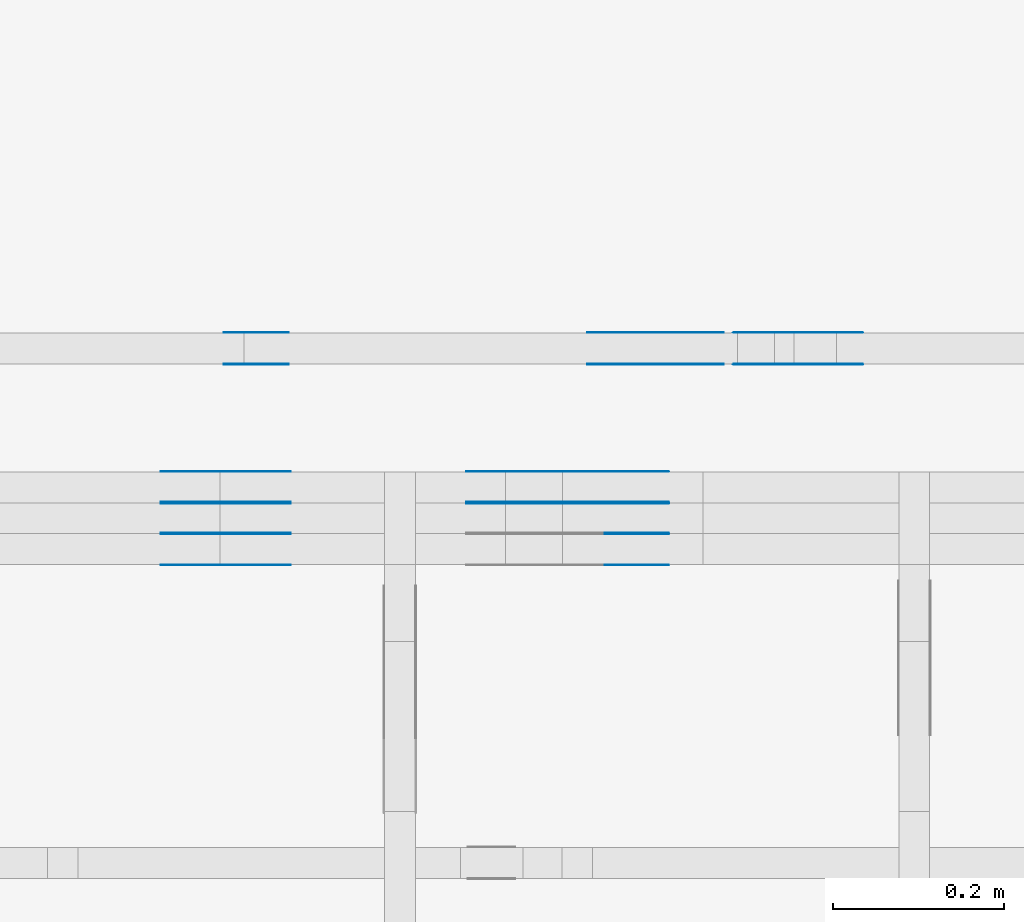
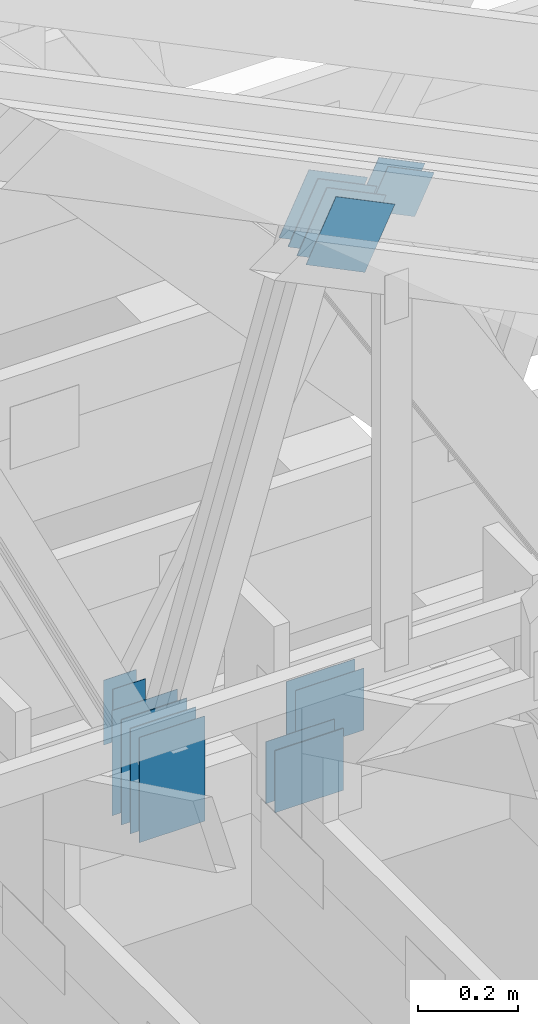
# One storey, part 127 of 159: 21 plates, 2 elements without a shape of their own.
"""IFC2X3 building model written with IfcOpenShell, lengths in millimetres."""

from ifc_helpers import new_model, si_unit, frame, origin, origin_with_axes, origin_2d, place, context, project, spatial, faceted_brep, element, aggregate, save


model = new_model("IFC2X3")

# Units and contexts
model_context = context("Model", 3, precision=1e-05, world=origin())
plan_context = context("Plan", 2, precision=1e-05, world=origin_2d())
ifc_project = project(units=[si_unit("LENGTHUNIT", "METRE", prefix="MILLI"), si_unit("AREAUNIT", "SQUARE_METRE"), si_unit("VOLUMEUNIT", "CUBIC_METRE"), si_unit("SOLIDANGLEUNIT", "STERADIAN"), si_unit("PLANEANGLEUNIT", "RADIAN"), si_unit("MASSUNIT", "GRAM"), si_unit("TIMEUNIT", "SECOND"), si_unit("THERMODYNAMICTEMPERATUREUNIT", "DEGREE_CELSIUS"), si_unit("LUMINOUSINTENSITYUNIT", "LUMEN")], contexts=[model_context, plan_context])

# Site, building, storey
site_placement = place(None, origin_with_axes())
site = spatial("IfcSite", under=ifc_project, at=site_placement, CompositionType="ELEMENT")
building_placement = place(site_placement, origin_with_axes())
building = spatial("IfcBuilding", under=site, at=building_placement, Name="Plan 1", CompositionType="ELEMENT")
storey_placement = place(building_placement, origin_with_axes())
storey = spatial("IfcBuildingStorey", under=building, at=storey_placement, Name="Etasje 1", CompositionType="ELEMENT", Elevation=0.0)

# Assembly, plates
assembly_1_placement = place(storey_placement, frame((10700.012663101485, 8801.999999990367, 0.0), z_axis=(0.0, -1.0, 6.123031769111886e-17), x_axis=(1.0, 0.0, 0.0)))
assembly_1 = element("IfcElementAssembly", 1, at=assembly_1_placement, inside=storey, Name="T8 (1)", AssemblyPlace="FACTORY", PredefinedType="TRUSS")
plate_1_placement = place(assembly_1_placement, frame((5070.5, 146.99999999999977, -73.0), z_axis=(0.0, 0.0, 1.0), x_axis=(1.0, 0.0, 0.0)))
plate_1 = element("IfcPlate", 2, at=plate_1_placement, Name="GNT100S 152x159", context=model_context, shape_type="Brep", body=[
    faceted_brep([(159.0, 152.00000000000023, 1.0), (0.0, 152.00000000000023, 1.0), (0.0, 2.2737367544323206e-13, 1.0), (159.0, 2.2737367544323206e-13, 1.0), (0.0, 152.00000000000023, 0.0), (159.0, 152.00000000000023, 1.9471241025775798e-14), (159.0, 2.2737367544323206e-13, 1.9471241025775798e-14), (0.0, 2.2737367544323206e-13, 0.0), (159.0, -2.92068615386637e-14, 1.788345410772899e-30), (159.0, -2.914563122097258e-14, 1.0), (1.1247455413666031e-32, 6.123031769111886e-17, 1.0), (0.0, 0.0, 0.0), (159.0, 152.0, 0.0), (159.0, 152.0, 1.0), (159.0, 0.0, 1.0), (159.0, 0.0, 0.0), (0.0, 152.0, 0.0), (-3.7491518045553436e-33, 152.0, 1.0), (159.0, 152.0, 1.0), (159.0, 152.0, 0.0), (0.0, 0.0, 0.0), (6.123031769111886e-17, -7.498303609110687e-33, 1.0), (1.8675246895791253e-14, 152.0, 1.0), (1.8614016578100134e-14, 152.0, -1.1397421485848245e-30)], [[[0, 1, 2, 3]], [[4, 5, 6, 7]], [[8, 9, 10, 11]], [[12, 13, 14, 15]], [[16, 17, 18, 19]], [[20, 21, 22, 23]]]),
])
plate_2_placement = place(assembly_1_placement, frame((5070.5, 146.99999999999977, -72.0), z_axis=(0.0, 0.0, 1.0), x_axis=(1.0, 0.0, 0.0)))
plate_2 = element("IfcPlate", 3, at=plate_2_placement, Name="GNT100S 152x159", context=model_context, shape_type="Brep", body=[
    faceted_brep([(159.0, 152.00000000000023, 1.0), (0.0, 152.00000000000023, 1.0), (0.0, 2.2737367544323206e-13, 1.0), (159.0, 2.2737367544323206e-13, 1.0), (0.0, 152.00000000000023, 0.0), (159.0, 152.00000000000023, 1.9471241025775798e-14), (159.0, 2.2737367544323206e-13, 1.9471241025775798e-14), (0.0, 2.2737367544323206e-13, 0.0), (159.0, -2.92068615386637e-14, 1.788345410772899e-30), (159.0, -2.914563122097258e-14, 1.0), (1.1247455413666031e-32, 6.123031769111886e-17, 1.0), (0.0, 0.0, 0.0), (159.0, 152.0, 0.0), (159.0, 152.0, 1.0), (159.0, 0.0, 1.0), (159.0, 0.0, 0.0), (0.0, 152.0, 0.0), (-3.7491518045553436e-33, 152.0, 1.0), (159.0, 152.0, 1.0), (159.0, 152.0, 0.0), (0.0, 0.0, 0.0), (6.123031769111886e-17, -7.498303609110687e-33, 1.0), (1.8675246895791253e-14, 152.0, 1.0), (1.8614016578100134e-14, 152.0, -1.1397421485848245e-30)], [[[0, 1, 2, 3]], [[4, 5, 6, 7]], [[8, 9, 10, 11]], [[12, 13, 14, 15]], [[16, 17, 18, 19]], [[20, 21, 22, 23]]]),
])
plate_3_placement = place(assembly_1_placement, frame((5070.5, 146.99999999999977, -109.0), z_axis=(0.0, 0.0, 1.0), x_axis=(1.0, 0.0, 0.0)))
plate_3 = element("IfcPlate", 4, at=plate_3_placement, Name="GNT100S 152x159", context=model_context, shape_type="Brep", body=[
    faceted_brep([(159.0, 152.00000000000023, 1.0), (0.0, 152.00000000000023, 1.0), (0.0, 2.2737367544323206e-13, 1.0), (159.0, 2.2737367544323206e-13, 1.0), (0.0, 152.00000000000023, 0.0), (159.0, 152.00000000000023, 1.9471241025775798e-14), (159.0, 2.2737367544323206e-13, 1.9471241025775798e-14), (0.0, 2.2737367544323206e-13, 0.0), (159.0, -2.92068615386637e-14, 1.788345410772899e-30), (159.0, -2.914563122097258e-14, 1.0), (1.1247455413666031e-32, 6.123031769111886e-17, 1.0), (0.0, 0.0, 0.0), (159.0, 152.0, 0.0), (159.0, 152.0, 1.0), (159.0, 0.0, 1.0), (159.0, 0.0, 0.0), (0.0, 152.0, 0.0), (-3.7491518045553436e-33, 152.0, 1.0), (159.0, 152.0, 1.0), (159.0, 152.0, 0.0), (0.0, 0.0, 0.0), (6.123031769111886e-17, -7.498303609110687e-33, 1.0), (1.8675246895791253e-14, 152.0, 1.0), (1.8614016578100134e-14, 152.0, -1.1397421485848245e-30)], [[[0, 1, 2, 3]], [[4, 5, 6, 7]], [[8, 9, 10, 11]], [[12, 13, 14, 15]], [[16, 17, 18, 19]], [[20, 21, 22, 23]]]),
])
plate_4_placement = place(assembly_1_placement, frame((5170.803078161007, 1667.5447482094141, 0.0), z_axis=(0.0, 0.0, 1.0), x_axis=(-0.4383711467890776, -0.8987940462991671, 0.0)))
plate_4 = element("IfcPlate", 5, at=plate_4_placement, Name="GNT100S 152x159", context=model_context, shape_type="Brep", body=[
    faceted_brep([(159.00016140741445, 152.00017854164298, 1.0), (2.6907896426564548e-05, 152.00017854164298, 1.0), (0.0, 0.00016076568863354623, 1.0), (159.00013449951803, 0.00016076568863354623, 1.0), (2.6907896426564548e-05, 152.00017854164298, 3.2951580931965386e-21), (159.00016140741445, 152.00017854164298, 1.9471260791830328e-14), (159.00013449951803, 4.886593887931667e-05, 1.9471257496672233e-14), (0.0, 4.886593887931667e-05, 0.0), (159.0001335586112, 9.593357614535953e-13, -3.0517839183092646e-30), (159.0001335586112, 9.593969917712864e-13, 1.0), (0.00013355861119634937, 6.12721837107411e-17, 1.0), (0.00013355861119634937, 4.18660196222441e-20, -2.563469681932617e-36), (159.0001335586112, 152.0000000000009, 0.0), (159.0001335586112, 152.0000000000009, 1.0), (159.0001335586112, 9.094947017729282e-13, 1.0), (159.0001335586112, 9.094947017729282e-13, 0.0), (0.00013355861119634937, 152.0, 0.0), (0.00013355861119634937, 152.0, 1.0), (159.0001335586112, 152.0000000000009, 1.0), (159.0001335586112, 152.0000000000009, 0.0), (0.00013355861119634937, 0.0, 0.0), (0.0001335586111964106, -7.498303609110687e-33, 1.0), (0.00013355861121502462, 152.0, 1.0), (0.0001335586112149634, 152.0, -1.1397427715968304e-30)], [[[0, 1, 2, 3]], [[4, 5, 6, 7]], [[8, 9, 10, 11]], [[12, 13, 14, 15]], [[16, 17, 18, 19]], [[20, 21, 22, 23]]]),
])
plate_5_placement = place(assembly_1_placement, frame((5170.803078161007, 1667.5447482094141, -37.00000000000001), z_axis=(0.0, 0.0, 1.0), x_axis=(-0.4383711467890776, -0.8987940462991671, 0.0)))
plate_5 = element("IfcPlate", 6, at=plate_5_placement, Name="GNT100S 152x159", context=model_context, shape_type="Brep", body=[
    faceted_brep([(159.00016140741445, 152.00017854164298, 1.0), (2.6907896426564548e-05, 152.00017854164298, 1.0), (0.0, 0.00016076568863354623, 1.0), (159.00013449951803, 0.00016076568863354623, 1.0), (2.6907896426564548e-05, 152.00017854164298, 3.2951580931965386e-21), (159.00016140741445, 152.00017854164298, 1.9471260791830328e-14), (159.00013449951803, 4.886593887931667e-05, 1.9471257496672233e-14), (0.0, 4.886593887931667e-05, 0.0), (159.0001335586112, 9.593357614535953e-13, -3.0517839183092646e-30), (159.0001335586112, 9.593969917712864e-13, 1.0), (0.00013355861119634937, 6.12721837107411e-17, 1.0), (0.00013355861119634937, 4.18660196222441e-20, -2.563469681932617e-36), (159.0001335586112, 152.0000000000009, 0.0), (159.0001335586112, 152.0000000000009, 1.0), (159.0001335586112, 9.094947017729282e-13, 1.0), (159.0001335586112, 9.094947017729282e-13, 0.0), (0.00013355861119634937, 152.0, 0.0), (0.00013355861119634937, 152.0, 1.0), (159.0001335586112, 152.0000000000009, 1.0), (159.0001335586112, 152.0000000000009, 0.0), (0.00013355861119634937, 0.0, 0.0), (0.0001335586111964106, -7.498303609110687e-33, 1.0), (0.00013355861121502462, 152.0, 1.0), (0.0001335586112149634, 152.0, -1.1397427715968304e-30)], [[[0, 1, 2, 3]], [[4, 5, 6, 7]], [[8, 9, 10, 11]], [[12, 13, 14, 15]], [[16, 17, 18, 19]], [[20, 21, 22, 23]]]),
])
plate_6_placement = place(assembly_1_placement, frame((5170.803078161007, 1667.5447482094141, -36.00000000000001), z_axis=(0.0, 0.0, 1.0), x_axis=(-0.4383711467890776, -0.8987940462991671, 0.0)))
plate_6 = element("IfcPlate", 7, at=plate_6_placement, Name="GNT100S 152x159", context=model_context, shape_type="Brep", body=[
    faceted_brep([(159.00016140741445, 152.00017854164298, 1.0), (2.6907896426564548e-05, 152.00017854164298, 1.0), (0.0, 0.00016076568863354623, 1.0), (159.00013449951803, 0.00016076568863354623, 1.0), (2.6907896426564548e-05, 152.00017854164298, 3.2951580931965386e-21), (159.00016140741445, 152.00017854164298, 1.9471260791830328e-14), (159.00013449951803, 4.886593887931667e-05, 1.9471257496672233e-14), (0.0, 4.886593887931667e-05, 0.0), (159.0001335586112, 9.593357614535953e-13, -3.0517839183092646e-30), (159.0001335586112, 9.593969917712864e-13, 1.0), (0.00013355861119634937, 6.12721837107411e-17, 1.0), (0.00013355861119634937, 4.18660196222441e-20, -2.563469681932617e-36), (159.0001335586112, 152.0000000000009, 0.0), (159.0001335586112, 152.0000000000009, 1.0), (159.0001335586112, 9.094947017729282e-13, 1.0), (159.0001335586112, 9.094947017729282e-13, 0.0), (0.00013355861119634937, 152.0, 0.0), (0.00013355861119634937, 152.0, 1.0), (159.0001335586112, 152.0000000000009, 1.0), (159.0001335586112, 152.0000000000009, 0.0), (0.00013355861119634937, 0.0, 0.0), (0.0001335586111964106, -7.498303609110687e-33, 1.0), (0.00013355861121502462, 152.0, 1.0), (0.0001335586112149634, 152.0, -1.1397427715968304e-30)], [[[0, 1, 2, 3]], [[4, 5, 6, 7]], [[8, 9, 10, 11]], [[12, 13, 14, 15]], [[16, 17, 18, 19]], [[20, 21, 22, 23]]]),
])
plate_7_placement = place(assembly_1_placement, frame((5170.803078161007, 1667.5447482094141, -73.00000000000001), z_axis=(0.0, 0.0, 1.0), x_axis=(-0.4383711467890776, -0.8987940462991671, 0.0)))
plate_7 = element("IfcPlate", 8, at=plate_7_placement, Name="GNT100S 152x159", context=model_context, shape_type="Brep", body=[
    faceted_brep([(159.00016140741445, 152.00017854164298, 1.0), (2.6907896426564548e-05, 152.00017854164298, 1.0), (0.0, 0.00016076568863354623, 1.0), (159.00013449951803, 0.00016076568863354623, 1.0), (2.6907896426564548e-05, 152.00017854164298, 3.2951580931965386e-21), (159.00016140741445, 152.00017854164298, 1.9471260791830328e-14), (159.00013449951803, 4.886593887931667e-05, 1.9471257496672233e-14), (0.0, 4.886593887931667e-05, 0.0), (159.0001335586112, 9.593357614535953e-13, -3.0517839183092646e-30), (159.0001335586112, 9.593969917712864e-13, 1.0), (0.00013355861119634937, 6.12721837107411e-17, 1.0), (0.00013355861119634937, 4.18660196222441e-20, -2.563469681932617e-36), (159.0001335586112, 152.0000000000009, 0.0), (159.0001335586112, 152.0000000000009, 1.0), (159.0001335586112, 9.094947017729282e-13, 1.0), (159.0001335586112, 9.094947017729282e-13, 0.0), (0.00013355861119634937, 152.0, 0.0), (0.00013355861119634937, 152.0, 1.0), (159.0001335586112, 152.0000000000009, 1.0), (159.0001335586112, 152.0000000000009, 0.0), (0.00013355861119634937, 0.0, 0.0), (0.0001335586111964106, -7.498303609110687e-33, 1.0), (0.00013355861121502462, 152.0, 1.0), (0.0001335586112149634, 152.0, -1.1397427715968304e-30)], [[[0, 1, 2, 3]], [[4, 5, 6, 7]], [[8, 9, 10, 11]], [[12, 13, 14, 15]], [[16, 17, 18, 19]], [[20, 21, 22, 23]]]),
])
plate_8_placement = place(assembly_1_placement, frame((5170.803078161007, 1667.5447482094141, -72.00000000000001), z_axis=(0.0, 0.0, 1.0), x_axis=(-0.4383711467890776, -0.8987940462991671, 0.0)))
plate_8 = element("IfcPlate", 9, at=plate_8_placement, Name="GNT100S 152x159", context=model_context, shape_type="Brep", body=[
    faceted_brep([(159.00016140741445, 152.00017854164298, 1.0), (2.6907896426564548e-05, 152.00017854164298, 1.0), (0.0, 0.00016076568863354623, 1.0), (159.00013449951803, 0.00016076568863354623, 1.0), (2.6907896426564548e-05, 152.00017854164298, 3.2951580931965386e-21), (159.00016140741445, 152.00017854164298, 1.9471260791830328e-14), (159.00013449951803, 4.886593887931667e-05, 1.9471257496672233e-14), (0.0, 4.886593887931667e-05, 0.0), (159.0001335586112, 9.593357614535953e-13, -3.0517839183092646e-30), (159.0001335586112, 9.593969917712864e-13, 1.0), (0.00013355861119634937, 6.12721837107411e-17, 1.0), (0.00013355861119634937, 4.18660196222441e-20, -2.563469681932617e-36), (159.0001335586112, 152.0000000000009, 0.0), (159.0001335586112, 152.0000000000009, 1.0), (159.0001335586112, 9.094947017729282e-13, 1.0), (159.0001335586112, 9.094947017729282e-13, 0.0), (0.00013355861119634937, 152.0, 0.0), (0.00013355861119634937, 152.0, 1.0), (159.0001335586112, 152.0000000000009, 1.0), (159.0001335586112, 152.0000000000009, 0.0), (0.00013355861119634937, 0.0, 0.0), (0.0001335586111964106, -7.498303609110687e-33, 1.0), (0.00013355861121502462, 152.0, 1.0), (0.0001335586112149634, 152.0, -1.1397427715968304e-30)], [[[0, 1, 2, 3]], [[4, 5, 6, 7]], [[8, 9, 10, 11]], [[12, 13, 14, 15]], [[16, 17, 18, 19]], [[20, 21, 22, 23]]]),
])
plate_9_placement = place(assembly_1_placement, frame((5170.803078161007, 1667.5447482094141, -109.00000000000003), z_axis=(0.0, 0.0, 1.0), x_axis=(-0.4383711467890776, -0.8987940462991671, 0.0)))
plate_9 = element("IfcPlate", 10, at=plate_9_placement, Name="GNT100S 152x159", context=model_context, shape_type="Brep", body=[
    faceted_brep([(159.00016140741445, 152.00017854164298, 1.0), (2.6907896426564548e-05, 152.00017854164298, 1.0), (0.0, 0.00016076568863354623, 1.0), (159.00013449951803, 0.00016076568863354623, 1.0), (2.6907896426564548e-05, 152.00017854164298, 3.2951580931965386e-21), (159.00016140741445, 152.00017854164298, 1.9471260791830328e-14), (159.00013449951803, 4.886593887931667e-05, 1.9471257496672233e-14), (0.0, 4.886593887931667e-05, 0.0), (159.0001335586112, 9.593357614535953e-13, -3.0517839183092646e-30), (159.0001335586112, 9.593969917712864e-13, 1.0), (0.00013355861119634937, 6.12721837107411e-17, 1.0), (0.00013355861119634937, 4.18660196222441e-20, -2.563469681932617e-36), (159.0001335586112, 152.0000000000009, 0.0), (159.0001335586112, 152.0000000000009, 1.0), (159.0001335586112, 9.094947017729282e-13, 1.0), (159.0001335586112, 9.094947017729282e-13, 0.0), (0.00013355861119634937, 152.0, 0.0), (0.00013355861119634937, 152.0, 1.0), (159.0001335586112, 152.0000000000009, 1.0), (159.0001335586112, 152.0000000000009, 0.0), (0.00013355861119634937, 0.0, 0.0), (0.0001335586111964106, -7.498303609110687e-33, 1.0), (0.00013355861121502462, 152.0, 1.0), (0.0001335586112149634, 152.0, -1.1397427715968304e-30)], [[[0, 1, 2, 3]], [[4, 5, 6, 7]], [[8, 9, 10, 11]], [[12, 13, 14, 15]], [[16, 17, 18, 19]], [[20, 21, 22, 23]]]),
])
plate_10_placement = place(assembly_1_placement, frame((4866.0, 241.99999999999983, 0.0), z_axis=(0.0, 0.0, 1.0), x_axis=(6.123031769111886e-17, 1.0, 0.0)))
plate_10 = element("IfcPlate", 11, at=plate_10_placement, Name="GNT100S 152x258", context=model_context, shape_type="Brep", body=[
    faceted_brep([(258.00000000000017, 152.0, 1.0), (1.7053025658242404e-13, 152.0, 1.0), (1.7053025658242404e-13, 0.0, 1.0), (258.00000000000017, 0.0, 1.0), (1.7053025658242404e-13, 152.0, 2.0883243572979676e-29), (258.00000000000017, 152.0, 3.159484392861735e-14), (258.00000000000017, 0.0, 3.159484392861735e-14), (1.7053025658242404e-13, 0.0, 2.0883243572979676e-29), (258.0, 2.6810918394258587e-12, 2.901843496725836e-30), (258.0, 2.68115306974355e-12, 1.0), (1.1247455413666031e-32, 2.728545335636476e-12, 1.0), (0.0, 2.7284841053187847e-12, 0.0), (258.0, 152.00000000000273, 0.0), (258.0, 152.00000000000273, 1.0), (258.0, 2.7284841053187847e-12, 1.0), (258.0, 2.7284841053187847e-12, 0.0), (0.0, 152.00000000000273, 0.0), (-3.7491518045553436e-33, 152.00000000000273, 1.0), (258.0, 152.0000000000027, 1.0), (258.0, 152.0000000000027, -1.5777218104420236e-30), (3.341318971676748e-28, 2.7284841053187847e-12, -2.0459002214312988e-44), (6.1230317691453e-17, 2.7284841053187847e-12, 1.0), (1.8675246895791588e-14, 152.00000000000273, 1.0), (1.861401657810047e-14, 152.00000000000273, -1.139742148584845e-30)], [[[0, 1, 2, 3]], [[4, 5, 6, 7]], [[8, 9, 10, 11]], [[12, 13, 14, 15]], [[16, 17, 18, 19]], [[20, 21, 22, 23]]]),
])
plate_11_placement = place(assembly_1_placement, frame((4866.0, 241.99999999999983, -37.0), z_axis=(0.0, 0.0, 1.0), x_axis=(6.123031769111886e-17, 1.0, 0.0)))
plate_11 = element("IfcPlate", 12, at=plate_11_placement, Name="GNT100S 152x258", context=model_context, shape_type="Brep", body=[
    faceted_brep([(258.00000000000017, 152.0, 1.0), (1.7053025658242404e-13, 152.0, 1.0), (1.7053025658242404e-13, 0.0, 1.0), (258.00000000000017, 0.0, 1.0), (1.7053025658242404e-13, 152.0, 2.0883243572979676e-29), (258.00000000000017, 152.0, 3.159484392861735e-14), (258.00000000000017, 0.0, 3.159484392861735e-14), (1.7053025658242404e-13, 0.0, 2.0883243572979676e-29), (258.0, 2.6810918394258587e-12, 2.901843496725836e-30), (258.0, 2.68115306974355e-12, 1.0), (1.1247455413666031e-32, 2.728545335636476e-12, 1.0), (0.0, 2.7284841053187847e-12, 0.0), (258.0, 152.00000000000273, 0.0), (258.0, 152.00000000000273, 1.0), (258.0, 2.7284841053187847e-12, 1.0), (258.0, 2.7284841053187847e-12, 0.0), (0.0, 152.00000000000273, 0.0), (-3.7491518045553436e-33, 152.00000000000273, 1.0), (258.0, 152.0000000000027, 1.0), (258.0, 152.0000000000027, -1.5777218104420236e-30), (3.341318971676748e-28, 2.7284841053187847e-12, -2.0459002214312988e-44), (6.1230317691453e-17, 2.7284841053187847e-12, 1.0), (1.8675246895791588e-14, 152.00000000000273, 1.0), (1.861401657810047e-14, 152.00000000000273, -1.139742148584845e-30)], [[[0, 1, 2, 3]], [[4, 5, 6, 7]], [[8, 9, 10, 11]], [[12, 13, 14, 15]], [[16, 17, 18, 19]], [[20, 21, 22, 23]]]),
])
plate_12_placement = place(assembly_1_placement, frame((4866.0, 241.99999999999983, -36.0), z_axis=(0.0, 0.0, 1.0), x_axis=(6.123031769111886e-17, 1.0, 0.0)))
plate_12 = element("IfcPlate", 13, at=plate_12_placement, Name="GNT100S 152x258", context=model_context, shape_type="Brep", body=[
    faceted_brep([(258.00000000000017, 152.0, 1.0), (1.7053025658242404e-13, 152.0, 1.0), (1.7053025658242404e-13, 0.0, 1.0), (258.00000000000017, 0.0, 1.0), (1.7053025658242404e-13, 152.0, 2.0883243572979676e-29), (258.00000000000017, 152.0, 3.159484392861735e-14), (258.00000000000017, 0.0, 3.159484392861735e-14), (1.7053025658242404e-13, 0.0, 2.0883243572979676e-29), (258.0, 2.6810918394258587e-12, 2.901843496725836e-30), (258.0, 2.68115306974355e-12, 1.0), (1.1247455413666031e-32, 2.728545335636476e-12, 1.0), (0.0, 2.7284841053187847e-12, 0.0), (258.0, 152.00000000000273, 0.0), (258.0, 152.00000000000273, 1.0), (258.0, 2.7284841053187847e-12, 1.0), (258.0, 2.7284841053187847e-12, 0.0), (0.0, 152.00000000000273, 0.0), (-3.7491518045553436e-33, 152.00000000000273, 1.0), (258.0, 152.0000000000027, 1.0), (258.0, 152.0000000000027, -1.5777218104420236e-30), (3.341318971676748e-28, 2.7284841053187847e-12, -2.0459002214312988e-44), (6.1230317691453e-17, 2.7284841053187847e-12, 1.0), (1.8675246895791588e-14, 152.00000000000273, 1.0), (1.861401657810047e-14, 152.00000000000273, -1.139742148584845e-30)], [[[0, 1, 2, 3]], [[4, 5, 6, 7]], [[8, 9, 10, 11]], [[12, 13, 14, 15]], [[16, 17, 18, 19]], [[20, 21, 22, 23]]]),
])
plate_13_placement = place(assembly_1_placement, frame((4866.0, 241.99999999999983, -73.0), z_axis=(0.0, 0.0, 1.0), x_axis=(6.123031769111886e-17, 1.0, 0.0)))
plate_13 = element("IfcPlate", 14, at=plate_13_placement, Name="GNT100S 152x258", context=model_context, shape_type="Brep", body=[
    faceted_brep([(258.00000000000017, 152.0, 1.0), (1.7053025658242404e-13, 152.0, 1.0), (1.7053025658242404e-13, 0.0, 1.0), (258.00000000000017, 0.0, 1.0), (1.7053025658242404e-13, 152.0, 2.0883243572979676e-29), (258.00000000000017, 152.0, 3.159484392861735e-14), (258.00000000000017, 0.0, 3.159484392861735e-14), (1.7053025658242404e-13, 0.0, 2.0883243572979676e-29), (258.0, 2.6810918394258587e-12, 2.901843496725836e-30), (258.0, 2.68115306974355e-12, 1.0), (1.1247455413666031e-32, 2.728545335636476e-12, 1.0), (0.0, 2.7284841053187847e-12, 0.0), (258.0, 152.00000000000273, 0.0), (258.0, 152.00000000000273, 1.0), (258.0, 2.7284841053187847e-12, 1.0), (258.0, 2.7284841053187847e-12, 0.0), (0.0, 152.00000000000273, 0.0), (-3.7491518045553436e-33, 152.00000000000273, 1.0), (258.0, 152.0000000000027, 1.0), (258.0, 152.0000000000027, -1.5777218104420236e-30), (3.341318971676748e-28, 2.7284841053187847e-12, -2.0459002214312988e-44), (6.1230317691453e-17, 2.7284841053187847e-12, 1.0), (1.8675246895791588e-14, 152.00000000000273, 1.0), (1.861401657810047e-14, 152.00000000000273, -1.139742148584845e-30)], [[[0, 1, 2, 3]], [[4, 5, 6, 7]], [[8, 9, 10, 11]], [[12, 13, 14, 15]], [[16, 17, 18, 19]], [[20, 21, 22, 23]]]),
])
plate_14_placement = place(assembly_1_placement, frame((4866.0, 241.99999999999983, -72.0), z_axis=(0.0, 0.0, 1.0), x_axis=(6.123031769111886e-17, 1.0, 0.0)))
plate_14 = element("IfcPlate", 15, at=plate_14_placement, Name="GNT100S 152x258", context=model_context, shape_type="Brep", body=[
    faceted_brep([(258.00000000000017, 152.0, 1.0), (1.7053025658242404e-13, 152.0, 1.0), (1.7053025658242404e-13, 0.0, 1.0), (258.00000000000017, 0.0, 1.0), (1.7053025658242404e-13, 152.0, 2.0883243572979676e-29), (258.00000000000017, 152.0, 3.159484392861735e-14), (258.00000000000017, 0.0, 3.159484392861735e-14), (1.7053025658242404e-13, 0.0, 2.0883243572979676e-29), (258.0, 2.6810918394258587e-12, 2.901843496725836e-30), (258.0, 2.68115306974355e-12, 1.0), (1.1247455413666031e-32, 2.728545335636476e-12, 1.0), (0.0, 2.7284841053187847e-12, 0.0), (258.0, 152.00000000000273, 0.0), (258.0, 152.00000000000273, 1.0), (258.0, 2.7284841053187847e-12, 1.0), (258.0, 2.7284841053187847e-12, 0.0), (0.0, 152.00000000000273, 0.0), (-3.7491518045553436e-33, 152.00000000000273, 1.0), (258.0, 152.0000000000027, 1.0), (258.0, 152.0000000000027, -1.5777218104420236e-30), (3.341318971676748e-28, 2.7284841053187847e-12, -2.0459002214312988e-44), (6.1230317691453e-17, 2.7284841053187847e-12, 1.0), (1.8675246895791588e-14, 152.00000000000273, 1.0), (1.861401657810047e-14, 152.00000000000273, -1.139742148584845e-30)], [[[0, 1, 2, 3]], [[4, 5, 6, 7]], [[8, 9, 10, 11]], [[12, 13, 14, 15]], [[16, 17, 18, 19]], [[20, 21, 22, 23]]]),
])
plate_15_placement = place(assembly_1_placement, frame((4866.0, 241.99999999999983, -109.0), z_axis=(0.0, 0.0, 1.0), x_axis=(6.123031769111886e-17, 1.0, 0.0)))
plate_15 = element("IfcPlate", 16, at=plate_15_placement, Name="GNT100S 152x258", context=model_context, shape_type="Brep", body=[
    faceted_brep([(258.00000000000017, 152.0, 1.0), (1.7053025658242404e-13, 152.0, 1.0), (1.7053025658242404e-13, 0.0, 1.0), (258.00000000000017, 0.0, 1.0), (1.7053025658242404e-13, 152.0, 2.0883243572979676e-29), (258.00000000000017, 152.0, 3.159484392861735e-14), (258.00000000000017, 0.0, 3.159484392861735e-14), (1.7053025658242404e-13, 0.0, 2.0883243572979676e-29), (258.0, 2.6810918394258587e-12, 2.901843496725836e-30), (258.0, 2.68115306974355e-12, 1.0), (1.1247455413666031e-32, 2.728545335636476e-12, 1.0), (0.0, 2.7284841053187847e-12, 0.0), (258.0, 152.00000000000273, 0.0), (258.0, 152.00000000000273, 1.0), (258.0, 2.7284841053187847e-12, 1.0), (258.0, 2.7284841053187847e-12, 0.0), (0.0, 152.00000000000273, 0.0), (-3.7491518045553436e-33, 152.00000000000273, 1.0), (258.0, 152.0000000000027, 1.0), (258.0, 152.0000000000027, -1.5777218104420236e-30), (3.341318971676748e-28, 2.7284841053187847e-12, -2.0459002214312988e-44), (6.1230317691453e-17, 2.7284841053187847e-12, 1.0), (1.8675246895791588e-14, 152.00000000000273, 1.0), (1.861401657810047e-14, 152.00000000000273, -1.139742148584845e-30)], [[[0, 1, 2, 3]], [[4, 5, 6, 7]], [[8, 9, 10, 11]], [[12, 13, 14, 15]], [[16, 17, 18, 19]], [[20, 21, 22, 23]]]),
])
aggregate(assembly_1, [plate_1, plate_2, plate_3, plate_4, plate_5, plate_6, plate_7, plate_8, plate_9, plate_10, plate_11, plate_12, plate_13, plate_14, plate_15])

assembly_2_placement = place(storey_placement, frame((10000.012663278096, 9072.000080051337, 1.1021457184401395e-15), z_axis=(9.811600543477555e-09, 1.0, 6.123031769111886e-17), x_axis=(-1.0, 9.811600543477555e-09, 0.0)))
assembly_2 = element("IfcElementAssembly", 17, at=assembly_2_placement, inside=storey, Name="T9 (79)", AssemblyPlace="FACTORY", PredefinedType="TRUSS")
plate_16_placement = place(assembly_2_placement, frame((-5487.68017578125, 291.5, 0.0), z_axis=(0.0, 0.0, 1.0), x_axis=(6.123031769111886e-17, 1.0, 0.0)))
plate_16 = element("IfcPlate", 18, at=plate_16_placement, Name="GNT100S 76x159", context=model_context, shape_type="Brep", body=[
    faceted_brep([(159.0, 76.0, 1.0), (0.0, 76.0, 1.0), (0.0, 0.0, 1.0), (159.0, 0.0, 1.0), (0.0, 76.0, 0.0), (159.0, 76.0, 1.9471241025775798e-14), (159.0, 0.0, 1.9471241025775798e-14), (0.0, 0.0, 0.0), (159.00000000000034, 1.4522708366828188e-11, 1.788345410772899e-30), (159.00000000000034, 1.452276959714588e-11, 1.0), (3.410605131648481e-13, 1.4551976458684543e-11, 1.0), (3.410605131648481e-13, 1.4551915228366852e-11, 0.0), (159.00000000000034, 76.00000000001455, 0.0), (159.00000000000034, 76.00000000001455, 1.0), (159.00000000000034, 1.4551915228366852e-11, 1.0), (159.00000000000034, 1.4551915228366852e-11, 0.0), (3.410605131648481e-13, 76.00000000001455, 0.0), (3.410605131648481e-13, 76.00000000001455, 1.0), (159.00000000000034, 76.00000000001454, 1.0), (159.00000000000034, 76.00000000001454, -7.888609052210118e-31), (3.4106051316484986e-13, 1.4551915228366852e-11, -1.0930128021733573e-43), (3.41121743482541e-13, 1.4551915228366852e-11, 1.0), (3.5042875177159104e-13, 76.00000000001455, 1.0), (3.503675214538999e-13, 76.00000000001455, -5.698710742925215e-31)], [[[0, 1, 2, 3]], [[4, 5, 6, 7]], [[8, 9, 10, 11]], [[12, 13, 14, 15]], [[16, 17, 18, 19]], [[20, 21, 22, 23]]]),
])
plate_17_placement = place(assembly_2_placement, frame((-5487.68017578125, 291.5, -37.0), z_axis=(0.0, 0.0, 1.0), x_axis=(6.123031769111886e-17, 1.0, 0.0)))
plate_17 = element("IfcPlate", 19, at=plate_17_placement, Name="GNT100S 76x159", context=model_context, shape_type="Brep", body=[
    faceted_brep([(159.0, 76.0, 1.0), (0.0, 76.0, 1.0), (0.0, 0.0, 1.0), (159.0, 0.0, 1.0), (0.0, 76.0, 0.0), (159.0, 76.0, 1.9471241025775798e-14), (159.0, 0.0, 1.9471241025775798e-14), (0.0, 0.0, 0.0), (159.00000000000034, 1.4522708366828188e-11, 1.788345410772899e-30), (159.00000000000034, 1.452276959714588e-11, 1.0), (3.410605131648481e-13, 1.4551976458684543e-11, 1.0), (3.410605131648481e-13, 1.4551915228366852e-11, 0.0), (159.00000000000034, 76.00000000001455, 0.0), (159.00000000000034, 76.00000000001455, 1.0), (159.00000000000034, 1.4551915228366852e-11, 1.0), (159.00000000000034, 1.4551915228366852e-11, 0.0), (3.410605131648481e-13, 76.00000000001455, 0.0), (3.410605131648481e-13, 76.00000000001455, 1.0), (159.00000000000034, 76.00000000001454, 1.0), (159.00000000000034, 76.00000000001454, -7.888609052210118e-31), (3.4106051316484986e-13, 1.4551915228366852e-11, -1.0930128021733573e-43), (3.41121743482541e-13, 1.4551915228366852e-11, 1.0), (3.5042875177159104e-13, 76.00000000001455, 1.0), (3.503675214538999e-13, 76.00000000001455, -5.698710742925215e-31)], [[[0, 1, 2, 3]], [[4, 5, 6, 7]], [[8, 9, 10, 11]], [[12, 13, 14, 15]], [[16, 17, 18, 19]], [[20, 21, 22, 23]]]),
])
plate_18_placement = place(assembly_2_placement, frame((-6070.824358851296, 147.0, 0.0), z_axis=(0.0, 0.0, 1.0), x_axis=(1.0, 0.0, 0.0)))
plate_18 = element("IfcPlate", 20, at=plate_18_placement, Name="GNT100S 152x159", context=model_context, shape_type="Brep", body=[
    faceted_brep([(159.00014010129598, 152.0, 1.0), (0.000140101295983186, 152.0, 1.0), (0.000140101295983186, 0.0, 1.0), (159.00014010129598, 0.0, 1.0), (0.000140101295983186, 152.0, 1.7156893723975907e-20), (159.00014010129598, 152.0, 1.9471258182669523e-14), (159.00014010129598, 0.0, 1.9471258182669523e-14), (0.000140101295983186, 0.0, 1.7156893723975907e-20), (159.0, -2.92068615386637e-14, 1.788345410772899e-30), (159.0, -2.914563122097258e-14, 1.0), (1.1247455413666031e-32, 6.123031769111886e-17, 1.0), (0.0, 0.0, 0.0), (159.0, 152.0, 0.0), (159.0, 152.0, 1.0), (159.0, 0.0, 1.0), (159.0, 0.0, 0.0), (0.0, 152.0, 0.0), (-3.7491518045553436e-33, 152.0, 1.0), (159.0, 152.0, 1.0), (159.0, 152.0, 0.0), (0.0, 0.0, 0.0), (6.123031769111886e-17, -7.498303609110687e-33, 1.0), (1.8675246895791253e-14, 152.0, 1.0), (1.8614016578100134e-14, 152.0, -1.1397421485848245e-30)], [[[0, 1, 2, 3]], [[4, 5, 6, 7]], [[8, 9, 10, 11]], [[12, 13, 14, 15]], [[16, 17, 18, 19]], [[20, 21, 22, 23]]]),
])
plate_19_placement = place(assembly_2_placement, frame((-6070.824358851296, 147.0, -37.0), z_axis=(0.0, 0.0, 1.0), x_axis=(1.0, 0.0, 0.0)))
plate_19 = element("IfcPlate", 21, at=plate_19_placement, Name="GNT100S 152x159", context=model_context, shape_type="Brep", body=[
    faceted_brep([(159.00014010129598, 152.0, 1.0), (0.000140101295983186, 152.0, 1.0), (0.000140101295983186, 0.0, 1.0), (159.00014010129598, 0.0, 1.0), (0.000140101295983186, 152.0, 1.7156893723975907e-20), (159.00014010129598, 152.0, 1.9471258182669523e-14), (159.00014010129598, 0.0, 1.9471258182669523e-14), (0.000140101295983186, 0.0, 1.7156893723975907e-20), (159.0, -2.92068615386637e-14, 1.788345410772899e-30), (159.0, -2.914563122097258e-14, 1.0), (1.1247455413666031e-32, 6.123031769111886e-17, 1.0), (0.0, 0.0, 0.0), (159.0, 152.0, 0.0), (159.0, 152.0, 1.0), (159.0, 0.0, 1.0), (159.0, 0.0, 0.0), (0.0, 152.0, 0.0), (-3.7491518045553436e-33, 152.0, 1.0), (159.0, 152.0, 1.0), (159.0, 152.0, 0.0), (0.0, 0.0, 0.0), (6.123031769111886e-17, -7.498303609110687e-33, 1.0), (1.8675246895791253e-14, 152.0, 1.0), (1.8614016578100134e-14, 152.0, -1.1397421485848245e-30)], [[[0, 1, 2, 3]], [[4, 5, 6, 7]], [[8, 9, 10, 11]], [[12, 13, 14, 15]], [[16, 17, 18, 19]], [[20, 21, 22, 23]]]),
])
plate_20_placement = place(assembly_2_placement, frame((-6126.717322090318, 1509.905105022936, 0.0), z_axis=(0.0, 0.0, 1.0), x_axis=(-0.8987940462991673, -0.4383711467890769, 0.0)))
plate_20 = element("IfcPlate", 22, at=plate_20_placement, Name="GNT100S 103x119", context=model_context, shape_type="Brep", body=[
    faceted_brep([(119.00037685730967, 102.99993787666108, 1.0), (0.00034321920429647435, 102.99993787666108, 1.0), (0.0, 8.425296255154535e-05, 1.0), (119.00003363810447, 8.425296255154535e-05, 1.0), (0.00034321920429647435, 102.99993787666108, 4.2030841833532305e-20), (119.00037685730967, 102.99993787666108, 1.457286176067188e-14), (119.00003363810447, 3.583412535590469e-05, 1.4572819729829934e-14), (0.0, 3.583412535590469e-05, 0.0), (119.00021950950577, -2.1859263737639758e-14, 1.3384496631496367e-30), (119.00021950950577, -2.179803341994864e-14, 1.0), (0.0002195095057686558, 6.118999578079556e-17, 1.0), (0.0002195095057686558, -4.032191032330585e-20, 2.4689233790088225e-36), (119.00021950950577, 103.0, 0.0), (119.00021950950577, 103.0, 1.0), (119.00021950950577, 0.0, 1.0), (119.00021950950577, 0.0, 0.0), (0.0002195095057686558, 103.0, 0.0), (0.0002195095057686558, 103.0, 1.0), (119.00021950950577, 102.99999999999999, 1.0), (119.00021950950577, 102.99999999999999, -7.888609052210118e-31), (0.0002195095057686558, 0.0, 0.0), (0.00021950950576871703, -7.498303609110687e-33, 1.0), (0.00021950950578133048, 103.0, 1.0), (0.00021950950578126924, 103.0, -7.723249910891245e-31)], [[[0, 1, 2, 3]], [[4, 5, 6, 7]], [[8, 9, 10, 11]], [[12, 13, 14, 15]], [[16, 17, 18, 19]], [[20, 21, 22, 23]]]),
])
plate_21_placement = place(assembly_2_placement, frame((-6126.717322090318, 1509.905105022936, -37.0), z_axis=(0.0, 0.0, 1.0), x_axis=(-0.8987940462991673, -0.4383711467890769, 0.0)))
plate_21 = element("IfcPlate", 23, at=plate_21_placement, Name="GNT100S 103x119", context=model_context, shape_type="Brep", body=[
    faceted_brep([(119.00037685730967, 102.99993787666108, 1.0), (0.00034321920429647435, 102.99993787666108, 1.0), (0.0, 8.425296255154535e-05, 1.0), (119.00003363810447, 8.425296255154535e-05, 1.0), (0.00034321920429647435, 102.99993787666108, 4.2030841833532305e-20), (119.00037685730967, 102.99993787666108, 1.457286176067188e-14), (119.00003363810447, 3.583412535590469e-05, 1.4572819729829934e-14), (0.0, 3.583412535590469e-05, 0.0), (119.00021950950577, -2.1859263737639758e-14, 1.3384496631496367e-30), (119.00021950950577, -2.179803341994864e-14, 1.0), (0.0002195095057686558, 6.118999578079556e-17, 1.0), (0.0002195095057686558, -4.032191032330585e-20, 2.4689233790088225e-36), (119.00021950950577, 103.0, 0.0), (119.00021950950577, 103.0, 1.0), (119.00021950950577, 0.0, 1.0), (119.00021950950577, 0.0, 0.0), (0.0002195095057686558, 103.0, 0.0), (0.0002195095057686558, 103.0, 1.0), (119.00021950950577, 102.99999999999999, 1.0), (119.00021950950577, 102.99999999999999, -7.888609052210118e-31), (0.0002195095057686558, 0.0, 0.0), (0.00021950950576871703, -7.498303609110687e-33, 1.0), (0.00021950950578133048, 103.0, 1.0), (0.00021950950578126924, 103.0, -7.723249910891245e-31)], [[[0, 1, 2, 3]], [[4, 5, 6, 7]], [[8, 9, 10, 11]], [[12, 13, 14, 15]], [[16, 17, 18, 19]], [[20, 21, 22, 23]]]),
])
aggregate(assembly_2, [plate_16, plate_17, plate_18, plate_19, plate_20, plate_21])

save(model, "model.ifc")
